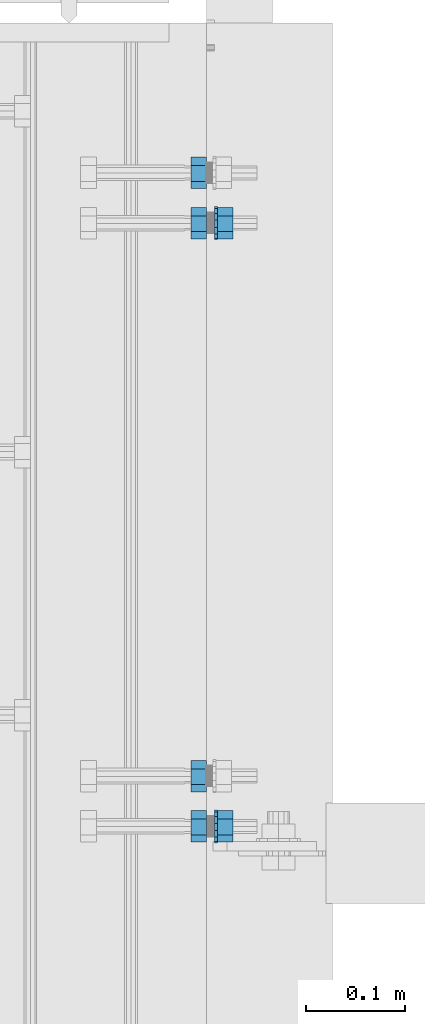
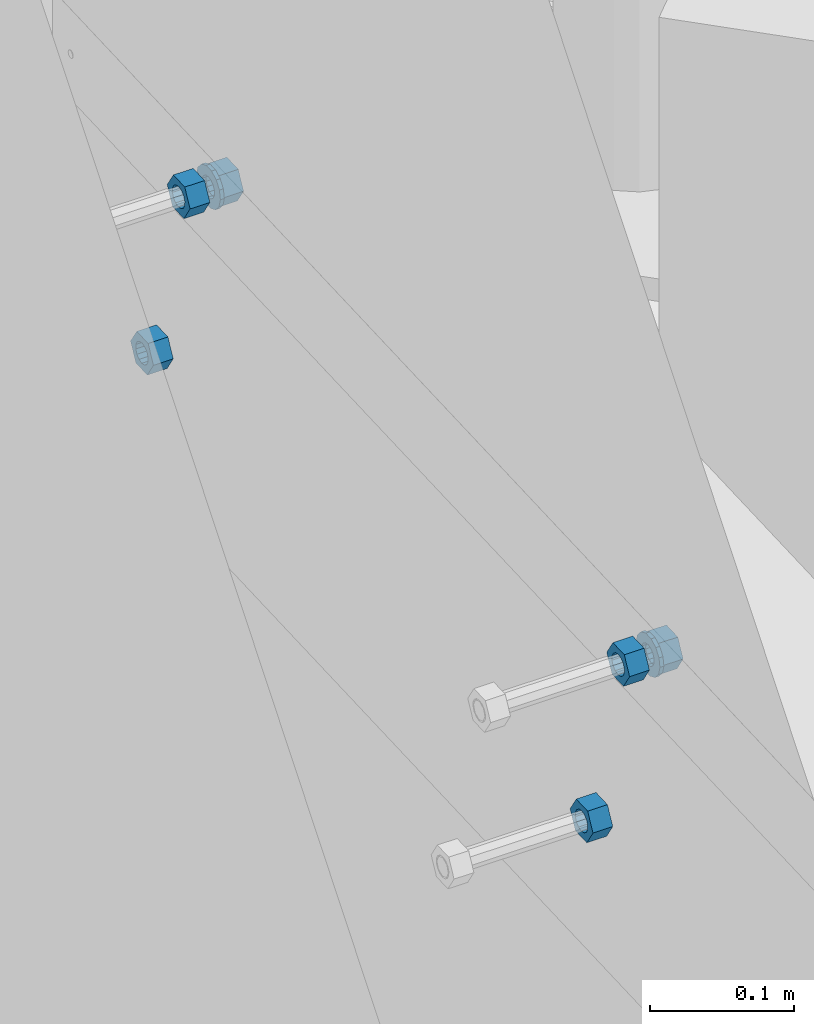
# One storey, part 718 of 975: 8 beams.
"""IFC2X3 building model written with IfcOpenShell, lengths in millimetres."""

from ifc_helpers import new_model, si_unit, frame, origin_with_axes, place, context, subcontext, project, spatial, faceted_brep, material, type_object, element, save


model = new_model("IFC2X3")

# Units and contexts
model_context = context("Model", 3, precision=1e-05, world=origin_with_axes())
body_context = subcontext(model_context, "Body", "Model", "MODEL_VIEW")
ifc_project = project(units=[si_unit("LENGTHUNIT", "METRE", prefix="MILLI"), si_unit("AREAUNIT", "SQUARE_METRE"), si_unit("VOLUMEUNIT", "CUBIC_METRE"), si_unit("MASSUNIT", "GRAM", prefix="KILO"), si_unit("TIMEUNIT", "SECOND"), si_unit("PLANEANGLEUNIT", "RADIAN"), si_unit("SOLIDANGLEUNIT", "STERADIAN"), si_unit("THERMODYNAMICTEMPERATUREUNIT", "DEGREE_CELSIUS"), si_unit("LUMINOUSINTENSITYUNIT", "LUMEN")], contexts=[model_context])

# Site, building, storey
site_placement = place(None, origin_with_axes())
site = spatial("IfcSite", under=ifc_project, at=site_placement, CompositionType="ELEMENT")
building_placement = place(site_placement, origin_with_axes())
building = spatial("IfcBuilding", under=site, at=building_placement, Name="Undefined", CompositionType="ELEMENT")
storey_placement = place(building_placement, origin_with_axes())
storey = spatial("IfcBuildingStorey", under=building, at=storey_placement, Name="Undefined", CompositionType="ELEMENT", Elevation=0.0)

# Beams
ifc_material = material(Name="STEEL/F1554-36")
beam_type_1 = type_object("IfcBeamType", Name="5/8_HEAVY_HEX_NUT", PredefinedType="NOTDEFINED")
beam_1_placement = place(storey_placement, frame((29959.2999142996, 4090.67007810735, 6995.95564941573), z_axis=(3.96407267544419e-09, 0.0430877640020053, -0.999071291046494), x_axis=(-0.999999999999998, 6.90000001668524e-08, 0.0)))
element("IfcBeam", 1, at=beam_1_placement, inside=storey, type_object=beam_type_1, material=ifc_material, Name="HEADED_ANCHOR_BOLT", ObjectType="5/8_HEAVY_HEX_NUT", context=body_context, shape_type="Brep", body=[
    faceted_brep([(-1.09139364212751e-11, -15.8800001144436, -2.72848410531878e-12), (1.45519152283669e-11, -7.94000005722046, -13.7500000000036), (15.8750000000146, -7.94000005722137, -13.7500000000045), (15.8749999999891, -15.8800001144446, -2.72848410531878e-12), (2.91038304567337e-11, 7.94000005722319, -13.7500000000027), (15.8750000000291, 7.94000005722319, -13.7500000000027), (2.18278728425503e-11, 15.8800001144436, 9.09494701772928e-13), (15.8750000000218, 15.8800001144427, 9.09494701772928e-13), (-7.27595761418343e-12, 7.94000005722046, 13.7500000000027), (15.8749999999927, 7.94000005722046, 13.7500000000027), (-2.18278728425503e-11, -7.94000005722228, 13.7500000000009), (15.8749999999782, -7.94000005722319, 13.7500000000009), (-7.27595761418343e-12, 0.0, 8.72999954223724), (0.0, 3.78780484388062, 7.86545780435881), (15.875, 3.78780484387971, 7.86545780435881), (15.8749999999927, -9.09494701772928e-13, 8.72999954223724), (7.27595761418343e-12, 6.82538848405238, 5.44306568481716), (15.8750000000073, 6.82538848405238, 5.44306568481716), (1.09139364212751e-11, 8.51112022706275, 1.94260765157742), (15.8750000000109, 8.51112022706093, 1.94260765157651), (1.45519152283669e-11, 8.51112022706184, -1.94260765157651), (15.8750000000146, 8.51112022706184, -1.94260765157651), (2.18278728425503e-11, 6.8253884840542, -5.44306568481716), (15.8750000000218, 6.82538848405238, -5.44306568481716), (1.81898940354586e-11, 3.78780484388153, -7.86545780435881), (15.8750000000182, 3.78780484388062, -7.86545780435881), (1.81898940354586e-11, 9.09494701772928e-13, -8.72999954223997), (15.8750000000182, 9.09494701772928e-13, -8.72999954223997), (1.09139364212751e-11, -3.78780484387971, -7.86545780436063), (15.8750000000109, -3.78780484388062, -7.86545780436063), (3.63797880709171e-12, -6.82538848405238, -5.44306568481807), (15.8750000000036, -6.82538848405329, -5.44306568481807), (0.0, -8.51112022706184, -1.94260765157833), (15.875, -8.51112022706184, -1.94260765157833), (-7.27595761418343e-12, -8.51112022706184, 1.9426076515756), (15.8749999999927, -8.51112022706275, 1.9426076515756), (-1.09139364212751e-11, -6.82538848405329, 5.44306568481534), (15.8749999999927, -6.8253884840542, 5.44306568481534), (-7.27595761418343e-12, -3.78780484388062, 7.8654578043579), (15.8749999999927, -3.78780484388153, 7.8654578043579)], [[[0, 1, 2, 3]], [[1, 4, 5, 2]], [[4, 6, 7, 5]], [[6, 8, 9, 7]], [[8, 10, 11, 9]], [[10, 0, 3, 11]], [[12, 13, 14, 15]], [[13, 16, 17, 14]], [[16, 18, 19, 17]], [[18, 20, 21, 19]], [[20, 22, 23, 21]], [[22, 24, 25, 23]], [[24, 26, 27, 25]], [[26, 28, 29, 27]], [[28, 30, 31, 29]], [[30, 32, 33, 31]], [[32, 34, 35, 33]], [[34, 36, 37, 35]], [[36, 38, 39, 37]], [[38, 12, 15, 39]], [[5, 7, 9, 11, 3, 2], [17, 19, 21, 23, 25, 27, 29, 31, 33, 35, 37, 39, 15, 14]], [[10, 8, 6, 4, 1, 0], [38, 36, 34, 32, 30, 28, 26, 24, 22, 20, 18, 16, 13, 12]]]),
])
beam_2_placement = place(storey_placement, frame((29959.299898448, 3481.63621908544, 6969.68934848015), z_axis=(3.96407267544419e-09, 0.0430877640020053, -0.999071291046494), x_axis=(-0.999999999999998, 6.90000001668524e-08, 0.0)))
element("IfcBeam", 2, at=beam_2_placement, inside=storey, type_object=beam_type_1, material=ifc_material, Name="HEADED_ANCHOR_BOLT", ObjectType="5/8_HEAVY_HEX_NUT", context=body_context, shape_type="Brep", body=[
    faceted_brep([(-1.09139364212751e-11, -15.8800001144436, -2.72848410531878e-12), (1.45519152283669e-11, -7.94000005722046, -13.7500000000036), (15.8750000000146, -7.94000005722137, -13.7500000000045), (15.8749999999891, -15.8800001144446, -2.72848410531878e-12), (2.91038304567337e-11, 7.94000005722319, -13.7500000000027), (15.8750000000291, 7.94000005722319, -13.7500000000027), (2.18278728425503e-11, 15.8800001144436, 9.09494701772928e-13), (15.8750000000218, 15.8800001144427, 9.09494701772928e-13), (-7.27595761418343e-12, 7.94000005722046, 13.7500000000027), (15.8749999999927, 7.94000005722046, 13.7500000000027), (-2.18278728425503e-11, -7.94000005722228, 13.7500000000009), (15.8749999999782, -7.94000005722319, 13.7500000000009), (-7.27595761418343e-12, 0.0, 8.72999954223724), (0.0, 3.78780484388062, 7.86545780435881), (15.875, 3.78780484387971, 7.86545780435881), (15.8749999999927, -9.09494701772928e-13, 8.72999954223724), (7.27595761418343e-12, 6.82538848405238, 5.44306568481716), (15.8750000000073, 6.82538848405238, 5.44306568481716), (1.09139364212751e-11, 8.51112022706275, 1.94260765157742), (15.8750000000109, 8.51112022706093, 1.94260765157651), (1.45519152283669e-11, 8.51112022706184, -1.94260765157651), (15.8750000000146, 8.51112022706184, -1.94260765157651), (2.18278728425503e-11, 6.8253884840542, -5.44306568481716), (15.8750000000218, 6.82538848405238, -5.44306568481716), (1.81898940354586e-11, 3.78780484388153, -7.86545780435881), (15.8750000000182, 3.78780484388062, -7.86545780435881), (1.81898940354586e-11, 9.09494701772928e-13, -8.72999954223997), (15.8750000000182, 9.09494701772928e-13, -8.72999954223997), (1.09139364212751e-11, -3.78780484387971, -7.86545780436063), (15.8750000000109, -3.78780484388062, -7.86545780436063), (3.63797880709171e-12, -6.82538848405238, -5.44306568481807), (15.8750000000036, -6.82538848405329, -5.44306568481807), (0.0, -8.51112022706184, -1.94260765157833), (15.875, -8.51112022706184, -1.94260765157833), (-7.27595761418343e-12, -8.51112022706184, 1.9426076515756), (15.8749999999927, -8.51112022706275, 1.9426076515756), (-1.09139364212751e-11, -6.82538848405329, 5.44306568481534), (15.8749999999927, -6.8253884840542, 5.44306568481534), (-7.27595761418343e-12, -3.78780484388062, 7.8654578043579), (15.8749999999927, -3.78780484388153, 7.8654578043579)], [[[0, 1, 2, 3]], [[1, 4, 5, 2]], [[4, 6, 7, 5]], [[6, 8, 9, 7]], [[8, 10, 11, 9]], [[10, 0, 3, 11]], [[12, 13, 14, 15]], [[13, 16, 17, 14]], [[16, 18, 19, 17]], [[18, 20, 21, 19]], [[20, 22, 23, 21]], [[22, 24, 25, 23]], [[24, 26, 27, 25]], [[26, 28, 29, 27]], [[28, 30, 31, 29]], [[30, 32, 33, 31]], [[32, 34, 35, 33]], [[34, 36, 37, 35]], [[36, 38, 39, 37]], [[38, 12, 15, 39]], [[5, 7, 9, 11, 3, 2], [17, 19, 21, 23, 25, 27, 29, 31, 33, 35, 37, 39, 15, 14]], [[10, 8, 6, 4, 1, 0], [38, 36, 34, 32, 30, 28, 26, 24, 22, 20, 18, 16, 13, 12]]]),
])
beam_3_placement = place(storey_placement, frame((29959.2996283393, 4039.92666630224, 7159.02066960924), z_axis=(-7.0905516622588e-09, -0.0430877640020049, 0.999071291046494), x_axis=(-0.999999999999998, 6.90000001668524e-08, 0.0)))
element("IfcBeam", 3, at=beam_3_placement, inside=storey, type_object=beam_type_1, material=ifc_material, Name="HEADED_ANCHOR_BOLT", ObjectType="5/8_HEAVY_HEX_NUT", context=body_context, shape_type="Brep", body=[
    faceted_brep([(-1.09139364212751e-11, -15.8800001144436, -2.72848410531878e-12), (1.45519152283669e-11, -7.94000005722046, -13.7500000000036), (15.8750000000146, -7.94000005722137, -13.7500000000045), (15.8749999999891, -15.8800001144446, -2.72848410531878e-12), (2.91038304567337e-11, 7.94000005722319, -13.7500000000027), (15.8750000000291, 7.94000005722319, -13.7500000000027), (2.18278728425503e-11, 15.8800001144436, 9.09494701772928e-13), (15.8750000000218, 15.8800001144427, 9.09494701772928e-13), (-7.27595761418343e-12, 7.94000005722046, 13.7500000000027), (15.8749999999927, 7.94000005722046, 13.7500000000027), (-2.18278728425503e-11, -7.94000005722228, 13.7500000000009), (15.8749999999782, -7.94000005722319, 13.7500000000009), (-7.27595761418343e-12, 0.0, 8.72999954223724), (0.0, 3.78780484388062, 7.86545780435881), (15.875, 3.78780484387971, 7.86545780435881), (15.8749999999927, -9.09494701772928e-13, 8.72999954223724), (7.27595761418343e-12, 6.82538848405238, 5.44306568481716), (15.8750000000073, 6.82538848405238, 5.44306568481716), (1.09139364212751e-11, 8.51112022706275, 1.94260765157742), (15.8750000000109, 8.51112022706093, 1.94260765157651), (1.45519152283669e-11, 8.51112022706184, -1.94260765157651), (15.8750000000146, 8.51112022706184, -1.94260765157651), (2.18278728425503e-11, 6.8253884840542, -5.44306568481716), (15.8750000000218, 6.82538848405238, -5.44306568481716), (1.81898940354586e-11, 3.78780484388153, -7.86545780435881), (15.8750000000182, 3.78780484388062, -7.86545780435881), (1.81898940354586e-11, 9.09494701772928e-13, -8.72999954223997), (15.8750000000182, 9.09494701772928e-13, -8.72999954223997), (1.09139364212751e-11, -3.78780484387971, -7.86545780436063), (15.8750000000109, -3.78780484388062, -7.86545780436063), (3.63797880709171e-12, -6.82538848405238, -5.44306568481807), (15.8750000000036, -6.82538848405329, -5.44306568481807), (0.0, -8.51112022706184, -1.94260765157833), (15.875, -8.51112022706184, -1.94260765157833), (-7.27595761418343e-12, -8.51112022706184, 1.9426076515756), (15.8749999999927, -8.51112022706275, 1.9426076515756), (-1.09139364212751e-11, -6.82538848405329, 5.44306568481534), (15.8749999999927, -6.8253884840542, 5.44306568481534), (-7.27595761418343e-12, -3.78780484388062, 7.8654578043579), (15.8749999999927, -3.78780484388153, 7.8654578043579)], [[[0, 1, 2, 3]], [[1, 4, 5, 2]], [[4, 6, 7, 5]], [[6, 8, 9, 7]], [[8, 10, 11, 9]], [[10, 0, 3, 11]], [[12, 13, 14, 15]], [[13, 16, 17, 14]], [[16, 18, 19, 17]], [[18, 20, 21, 19]], [[20, 22, 23, 21]], [[22, 24, 25, 23]], [[24, 26, 27, 25]], [[26, 28, 29, 27]], [[28, 30, 31, 29]], [[30, 32, 33, 31]], [[32, 34, 35, 33]], [[34, 36, 37, 35]], [[36, 38, 39, 37]], [[38, 12, 15, 39]], [[5, 7, 9, 11, 3, 2], [17, 19, 21, 23, 25, 27, 29, 31, 33, 35, 37, 39, 15, 14]], [[10, 8, 6, 4, 1, 0], [38, 36, 34, 32, 30, 28, 26, 24, 22, 20, 18, 16, 13, 12]]]),
])
beam_4_placement = place(storey_placement, frame((29986.2871283396, 4039.92667104132, 7159.02066965644), z_axis=(-7.0905516622588e-09, -0.0430877640020049, 0.999071291046494), x_axis=(-0.999999999999998, 6.90000001668524e-08, 0.0)))
element("IfcBeam", 4, at=beam_4_placement, inside=storey, type_object=beam_type_1, material=ifc_material, Name="HEADED_ANCHOR_BOLT", ObjectType="5/8_HEAVY_HEX_NUT", context=body_context, shape_type="Brep", body=[
    faceted_brep([(-1.09139364212751e-11, -15.8800001144436, -2.72848410531878e-12), (1.45519152283669e-11, -7.94000005722046, -13.7500000000036), (15.8750000000146, -7.94000005722137, -13.7500000000045), (15.8749999999891, -15.8800001144446, -2.72848410531878e-12), (2.91038304567337e-11, 7.94000005722319, -13.7500000000027), (15.8750000000291, 7.94000005722319, -13.7500000000027), (2.18278728425503e-11, 15.8800001144436, 9.09494701772928e-13), (15.8750000000218, 15.8800001144427, 9.09494701772928e-13), (-7.27595761418343e-12, 7.94000005722046, 13.7500000000027), (15.8749999999927, 7.94000005722046, 13.7500000000027), (-2.18278728425503e-11, -7.94000005722228, 13.7500000000009), (15.8749999999782, -7.94000005722319, 13.7500000000009), (-7.27595761418343e-12, 0.0, 8.72999954223724), (0.0, 3.78780484388062, 7.86545780435881), (15.875, 3.78780484387971, 7.86545780435881), (15.8749999999927, -9.09494701772928e-13, 8.72999954223724), (7.27595761418343e-12, 6.82538848405238, 5.44306568481716), (15.8750000000073, 6.82538848405238, 5.44306568481716), (1.09139364212751e-11, 8.51112022706275, 1.94260765157742), (15.8750000000109, 8.51112022706093, 1.94260765157651), (1.45519152283669e-11, 8.51112022706184, -1.94260765157651), (15.8750000000146, 8.51112022706184, -1.94260765157651), (2.18278728425503e-11, 6.8253884840542, -5.44306568481716), (15.8750000000218, 6.82538848405238, -5.44306568481716), (1.81898940354586e-11, 3.78780484388153, -7.86545780435881), (15.8750000000182, 3.78780484388062, -7.86545780435881), (1.81898940354586e-11, 9.09494701772928e-13, -8.72999954223997), (15.8750000000182, 9.09494701772928e-13, -8.72999954223997), (1.09139364212751e-11, -3.78780484387971, -7.86545780436063), (15.8750000000109, -3.78780484388062, -7.86545780436063), (3.63797880709171e-12, -6.82538848405238, -5.44306568481807), (15.8750000000036, -6.82538848405329, -5.44306568481807), (0.0, -8.51112022706184, -1.94260765157833), (15.875, -8.51112022706184, -1.94260765157833), (-7.27595761418343e-12, -8.51112022706184, 1.9426076515756), (15.8749999999927, -8.51112022706275, 1.9426076515756), (-1.09139364212751e-11, -6.82538848405329, 5.44306568481534), (15.8749999999927, -6.8253884840542, 5.44306568481534), (-7.27595761418343e-12, -3.78780484388062, 7.8654578043579), (15.8749999999927, -3.78780484388153, 7.8654578043579)], [[[0, 1, 2, 3]], [[1, 4, 5, 2]], [[4, 6, 7, 5]], [[6, 8, 9, 7]], [[8, 10, 11, 9]], [[10, 0, 3, 11]], [[12, 13, 14, 15]], [[13, 16, 17, 14]], [[16, 18, 19, 17]], [[18, 20, 21, 19]], [[20, 22, 23, 21]], [[22, 24, 25, 23]], [[24, 26, 27, 25]], [[26, 28, 29, 27]], [[28, 30, 31, 29]], [[30, 32, 33, 31]], [[32, 34, 35, 33]], [[34, 36, 37, 35]], [[36, 38, 39, 37]], [[38, 12, 15, 39]], [[5, 7, 9, 11, 3, 2], [17, 19, 21, 23, 25, 27, 29, 31, 33, 35, 37, 39, 15, 14]], [[10, 8, 6, 4, 1, 0], [38, 36, 34, 32, 30, 28, 26, 24, 22, 20, 18, 16, 13, 12]]]),
])
beam_5_placement = place(storey_placement, frame((29959.2996801553, 3430.89283167165, 7132.75436972556), z_axis=(-7.0905516622588e-09, -0.0430877640020049, 0.999071291046494), x_axis=(-0.999999999999998, 6.90000001668524e-08, 0.0)))
element("IfcBeam", 5, at=beam_5_placement, inside=storey, type_object=beam_type_1, material=ifc_material, Name="HEADED_ANCHOR_BOLT", ObjectType="5/8_HEAVY_HEX_NUT", context=body_context, shape_type="Brep", body=[
    faceted_brep([(-1.09139364212751e-11, -15.8800001144436, -2.72848410531878e-12), (1.45519152283669e-11, -7.94000005722046, -13.7500000000036), (15.8750000000146, -7.94000005722137, -13.7500000000045), (15.8749999999891, -15.8800001144446, -2.72848410531878e-12), (2.91038304567337e-11, 7.94000005722319, -13.7500000000027), (15.8750000000291, 7.94000005722319, -13.7500000000027), (2.18278728425503e-11, 15.8800001144436, 9.09494701772928e-13), (15.8750000000218, 15.8800001144427, 9.09494701772928e-13), (-7.27595761418343e-12, 7.94000005722046, 13.7500000000027), (15.8749999999927, 7.94000005722046, 13.7500000000027), (-2.18278728425503e-11, -7.94000005722228, 13.7500000000009), (15.8749999999782, -7.94000005722319, 13.7500000000009), (-7.27595761418343e-12, 0.0, 8.72999954223724), (0.0, 3.78780484388062, 7.86545780435881), (15.875, 3.78780484387971, 7.86545780435881), (15.8749999999927, -9.09494701772928e-13, 8.72999954223724), (7.27595761418343e-12, 6.82538848405238, 5.44306568481716), (15.8750000000073, 6.82538848405238, 5.44306568481716), (1.09139364212751e-11, 8.51112022706275, 1.94260765157742), (15.8750000000109, 8.51112022706093, 1.94260765157651), (1.45519152283669e-11, 8.51112022706184, -1.94260765157651), (15.8750000000146, 8.51112022706184, -1.94260765157651), (2.18278728425503e-11, 6.8253884840542, -5.44306568481716), (15.8750000000218, 6.82538848405238, -5.44306568481716), (1.81898940354586e-11, 3.78780484388153, -7.86545780435881), (15.8750000000182, 3.78780484388062, -7.86545780435881), (1.81898940354586e-11, 9.09494701772928e-13, -8.72999954223997), (15.8750000000182, 9.09494701772928e-13, -8.72999954223997), (1.09139364212751e-11, -3.78780484387971, -7.86545780436063), (15.8750000000109, -3.78780484388062, -7.86545780436063), (3.63797880709171e-12, -6.82538848405238, -5.44306568481807), (15.8750000000036, -6.82538848405329, -5.44306568481807), (0.0, -8.51112022706184, -1.94260765157833), (15.875, -8.51112022706184, -1.94260765157833), (-7.27595761418343e-12, -8.51112022706184, 1.9426076515756), (15.8749999999927, -8.51112022706275, 1.9426076515756), (-1.09139364212751e-11, -6.82538848405329, 5.44306568481534), (15.8749999999927, -6.8253884840542, 5.44306568481534), (-7.27595761418343e-12, -3.78780484388062, 7.8654578043579), (15.8749999999927, -3.78780484388153, 7.8654578043579)], [[[0, 1, 2, 3]], [[1, 4, 5, 2]], [[4, 6, 7, 5]], [[6, 8, 9, 7]], [[8, 10, 11, 9]], [[10, 0, 3, 11]], [[12, 13, 14, 15]], [[13, 16, 17, 14]], [[16, 18, 19, 17]], [[18, 20, 21, 19]], [[20, 22, 23, 21]], [[22, 24, 25, 23]], [[24, 26, 27, 25]], [[26, 28, 29, 27]], [[28, 30, 31, 29]], [[30, 32, 33, 31]], [[32, 34, 35, 33]], [[34, 36, 37, 35]], [[36, 38, 39, 37]], [[38, 12, 15, 39]], [[5, 7, 9, 11, 3, 2], [17, 19, 21, 23, 25, 27, 29, 31, 33, 35, 37, 39, 15, 14]], [[10, 8, 6, 4, 1, 0], [38, 36, 34, 32, 30, 28, 26, 24, 22, 20, 18, 16, 13, 12]]]),
])
beam_6_placement = place(storey_placement, frame((29986.2871801556, 3430.89283641073, 7132.75436977276), z_axis=(-7.0905516622588e-09, -0.0430877640020049, 0.999071291046494), x_axis=(-0.999999999999998, 6.90000001668524e-08, 0.0)))
element("IfcBeam", 6, at=beam_6_placement, inside=storey, type_object=beam_type_1, material=ifc_material, Name="HEADED_ANCHOR_BOLT", ObjectType="5/8_HEAVY_HEX_NUT", context=body_context, shape_type="Brep", body=[
    faceted_brep([(-1.09139364212751e-11, -15.8800001144436, -2.72848410531878e-12), (1.45519152283669e-11, -7.94000005722046, -13.7500000000036), (15.8750000000146, -7.94000005722137, -13.7500000000045), (15.8749999999891, -15.8800001144446, -2.72848410531878e-12), (2.91038304567337e-11, 7.94000005722319, -13.7500000000027), (15.8750000000291, 7.94000005722319, -13.7500000000027), (2.18278728425503e-11, 15.8800001144436, 9.09494701772928e-13), (15.8750000000218, 15.8800001144427, 9.09494701772928e-13), (-7.27595761418343e-12, 7.94000005722046, 13.7500000000027), (15.8749999999927, 7.94000005722046, 13.7500000000027), (-2.18278728425503e-11, -7.94000005722228, 13.7500000000009), (15.8749999999782, -7.94000005722319, 13.7500000000009), (-7.27595761418343e-12, 0.0, 8.72999954223724), (0.0, 3.78780484388062, 7.86545780435881), (15.875, 3.78780484387971, 7.86545780435881), (15.8749999999927, -9.09494701772928e-13, 8.72999954223724), (7.27595761418343e-12, 6.82538848405238, 5.44306568481716), (15.8750000000073, 6.82538848405238, 5.44306568481716), (1.09139364212751e-11, 8.51112022706275, 1.94260765157742), (15.8750000000109, 8.51112022706093, 1.94260765157651), (1.45519152283669e-11, 8.51112022706184, -1.94260765157651), (15.8750000000146, 8.51112022706184, -1.94260765157651), (2.18278728425503e-11, 6.8253884840542, -5.44306568481716), (15.8750000000218, 6.82538848405238, -5.44306568481716), (1.81898940354586e-11, 3.78780484388153, -7.86545780435881), (15.8750000000182, 3.78780484388062, -7.86545780435881), (1.81898940354586e-11, 9.09494701772928e-13, -8.72999954223997), (15.8750000000182, 9.09494701772928e-13, -8.72999954223997), (1.09139364212751e-11, -3.78780484387971, -7.86545780436063), (15.8750000000109, -3.78780484388062, -7.86545780436063), (3.63797880709171e-12, -6.82538848405238, -5.44306568481807), (15.8750000000036, -6.82538848405329, -5.44306568481807), (0.0, -8.51112022706184, -1.94260765157833), (15.875, -8.51112022706184, -1.94260765157833), (-7.27595761418343e-12, -8.51112022706184, 1.9426076515756), (15.8749999999927, -8.51112022706275, 1.9426076515756), (-1.09139364212751e-11, -6.82538848405329, 5.44306568481534), (15.8749999999927, -6.8253884840542, 5.44306568481534), (-7.27595761418343e-12, -3.78780484388062, 7.8654578043579), (15.8749999999927, -3.78780484388153, 7.8654578043579)], [[[0, 1, 2, 3]], [[1, 4, 5, 2]], [[4, 6, 7, 5]], [[6, 8, 9, 7]], [[8, 10, 11, 9]], [[10, 0, 3, 11]], [[12, 13, 14, 15]], [[13, 16, 17, 14]], [[16, 18, 19, 17]], [[18, 20, 21, 19]], [[20, 22, 23, 21]], [[22, 24, 25, 23]], [[24, 26, 27, 25]], [[26, 28, 29, 27]], [[28, 30, 31, 29]], [[30, 32, 33, 31]], [[32, 34, 35, 33]], [[34, 36, 37, 35]], [[36, 38, 39, 37]], [[38, 12, 15, 39]], [[5, 7, 9, 11, 3, 2], [17, 19, 21, 23, 25, 27, 29, 31, 33, 35, 37, 39, 15, 14]], [[10, 8, 6, 4, 1, 0], [38, 36, 34, 32, 30, 28, 26, 24, 22, 20, 18, 16, 13, 12]]]),
])
beam_type_2 = type_object("IfcBeamType", Name="5/8_WASHER", PredefinedType="NOTDEFINED")
beam_7_placement = place(storey_placement, frame((29970.4121283397, 4039.92666819858, 7159.02066967837), z_axis=(-7.0905516622588e-09, -0.0430877640020049, 0.999071291046494), x_axis=(-0.999999999999998, 6.90000001668524e-08, 0.0)))
element("IfcBeam", 7, at=beam_7_placement, inside=storey, type_object=beam_type_2, material=ifc_material, Name="HEADED_ANCHOR_BOLT", ObjectType="5/8_WASHER", context=body_context, shape_type="Brep", body=[
    faceted_brep([(1.09139364212751e-11, -16.670000076293, -2.72848410531878e-12), (2.18278728425503e-11, -15.0191510966704, -7.23284196419536), (3.1750000000211, -15.0191510966711, -7.23284196419627), (3.17500000001019, -16.6700000762937, -1.81898940354586e-12), (2.91038304567337e-11, -10.3935750445523, -13.0331308723944), (3.17500000002838, -10.3935750445526, -13.0331308723953), (2.91038304567337e-11, -3.70942398602756, -16.2520483704566), (3.17500000002838, -3.70942398602779, -16.2520483704566), (2.5465851649642e-11, 3.70942398602961, -16.2520483704557), (3.17500000002474, 3.70942398602961, -16.2520483704566), (1.45519152283669e-11, 10.3935750445542, -13.0331308723935), (3.17500000001382, 10.3935750445537, -13.0331308723944), (0.0, 15.0191510966717, -7.23284196419354), (3.17499999999927, 15.0191510966713, -7.23284196419354), (-7.27595761418343e-12, 16.6700000762933, 0.0), (3.174999999992, 16.6700000762928, -9.09494701772928e-13), (-1.81898940354586e-11, 15.0191510966706, 7.23284196419354), (3.17499999998108, 15.0191510966704, 7.23284196419354), (-2.5465851649642e-11, 10.3935750445519, 13.0331308723926), (3.17499999997381, 10.3935750445517, 13.0331308723926), (-2.5465851649642e-11, 3.70942398602733, 16.2520483704538), (3.17499999997381, 3.7094239860271, 16.2520483704529), (-2.18278728425503e-11, -3.70942398602983, 16.2520483704529), (3.17499999997744, -3.70942398603006, 16.2520483704538), (-1.09139364212751e-11, -10.3935750445542, 13.0331308723908), (3.17499999998836, -10.3935750445544, 13.0331308723908), (0.0, -15.0191510966717, 7.23284196419172), (3.17499999999927, -15.019151096672, 7.23284196419081), (-7.27595761418343e-12, 0.0, 8.72999954223724), (0.0, 3.78780484388062, 7.86545780435881), (3.17499999998472, 3.78780484387903, 7.86545780435699), (3.17499999998836, -9.09494701772928e-13, 8.72999954223542), (7.27595761418343e-12, 6.82538848405238, 5.44306568481716), (3.17499999998836, 6.82538848405102, 5.44306568481534), (1.09139364212751e-11, 8.51112022706275, 1.94260765157742), (3.174999999992, 8.51112022705979, 1.94260765157651), (1.45519152283669e-11, 8.51112022706184, -1.94260765157651), (3.17499999999563, 8.51112022706025, -1.94260765157742), (2.18278728425503e-11, 6.8253884840542, -5.44306568481716), (3.17500000000655, 6.8253884840517, -5.44306568481807), (1.81898940354586e-11, 3.78780484388153, -7.86545780435881), (3.17500000001019, 3.78780484388017, -7.86545780435972), (1.81898940354586e-11, 9.09494701772928e-13, -8.72999954223997), (3.17500000001382, 6.82121026329696e-13, -8.72999954223997), (1.09139364212751e-11, -3.78780484387971, -7.86545780436063), (3.17500000001382, -3.78780484387994, -7.86545780436063), (3.63797880709171e-12, -6.82538848405238, -5.44306568481807), (3.17500000001019, -6.82538848405147, -5.44306568481898), (0.0, -8.51112022706184, -1.94260765157833), (3.17500000001019, -8.5111202270607, -1.94260765157924), (-7.27595761418343e-12, -8.51112022706184, 1.9426076515756), (3.17500000000291, -8.51112022706093, 1.94260765157469), (-1.09139364212751e-11, -6.82538848405329, 5.44306568481534), (3.17499999999563, -6.82538848405238, 5.44306568481534), (-7.27595761418343e-12, -3.78780484388062, 7.8654578043579), (3.174999999992, -3.78780484388085, 7.86545780435699)], [[[0, 1, 2, 3]], [[1, 4, 5, 2]], [[4, 6, 7, 5]], [[6, 8, 9, 7]], [[8, 10, 11, 9]], [[10, 12, 13, 11]], [[12, 14, 15, 13]], [[14, 16, 17, 15]], [[16, 18, 19, 17]], [[18, 20, 21, 19]], [[20, 22, 23, 21]], [[22, 24, 25, 23]], [[24, 26, 27, 25]], [[26, 0, 3, 27]], [[28, 29, 30, 31]], [[29, 32, 33, 30]], [[32, 34, 35, 33]], [[34, 36, 37, 35]], [[36, 38, 39, 37]], [[38, 40, 41, 39]], [[40, 42, 43, 41]], [[42, 44, 45, 43]], [[44, 46, 47, 45]], [[46, 48, 49, 47]], [[48, 50, 51, 49]], [[50, 52, 53, 51]], [[52, 54, 55, 53]], [[54, 28, 31, 55]], [[5, 7, 9, 11, 13, 15, 17, 19, 21, 23, 25, 27, 3, 2], [33, 35, 37, 39, 41, 43, 45, 47, 49, 51, 53, 55, 31, 30]], [[26, 24, 22, 20, 18, 16, 14, 12, 10, 8, 6, 4, 1, 0], [54, 52, 50, 48, 46, 44, 42, 40, 38, 36, 34, 32, 29, 28]]]),
])
beam_8_placement = place(storey_placement, frame((29970.4121801557, 3430.89283356799, 7132.75436979469), z_axis=(-7.0905516622588e-09, -0.0430877640020049, 0.999071291046494), x_axis=(-0.999999999999998, 6.90000001668524e-08, 0.0)))
element("IfcBeam", 8, at=beam_8_placement, inside=storey, type_object=beam_type_2, material=ifc_material, Name="HEADED_ANCHOR_BOLT", ObjectType="5/8_WASHER", context=body_context, shape_type="Brep", body=[
    faceted_brep([(1.09139364212751e-11, -16.670000076293, -2.72848410531878e-12), (2.18278728425503e-11, -15.0191510966704, -7.23284196419536), (3.1750000000211, -15.0191510966711, -7.23284196419627), (3.17500000001019, -16.6700000762937, -1.81898940354586e-12), (2.91038304567337e-11, -10.3935750445523, -13.0331308723944), (3.17500000002838, -10.3935750445526, -13.0331308723953), (2.91038304567337e-11, -3.70942398602756, -16.2520483704566), (3.17500000002838, -3.70942398602779, -16.2520483704566), (2.5465851649642e-11, 3.70942398602961, -16.2520483704557), (3.17500000002474, 3.70942398602961, -16.2520483704566), (1.45519152283669e-11, 10.3935750445542, -13.0331308723935), (3.17500000001382, 10.3935750445537, -13.0331308723944), (0.0, 15.0191510966717, -7.23284196419354), (3.17499999999927, 15.0191510966713, -7.23284196419354), (-7.27595761418343e-12, 16.6700000762933, 0.0), (3.174999999992, 16.6700000762928, -9.09494701772928e-13), (-1.81898940354586e-11, 15.0191510966706, 7.23284196419354), (3.17499999998108, 15.0191510966704, 7.23284196419354), (-2.5465851649642e-11, 10.3935750445519, 13.0331308723926), (3.17499999997381, 10.3935750445517, 13.0331308723926), (-2.5465851649642e-11, 3.70942398602733, 16.2520483704538), (3.17499999997381, 3.7094239860271, 16.2520483704529), (-2.18278728425503e-11, -3.70942398602983, 16.2520483704529), (3.17499999997744, -3.70942398603006, 16.2520483704538), (-1.09139364212751e-11, -10.3935750445542, 13.0331308723908), (3.17499999998836, -10.3935750445544, 13.0331308723908), (0.0, -15.0191510966717, 7.23284196419172), (3.17499999999927, -15.019151096672, 7.23284196419081), (-7.27595761418343e-12, 0.0, 8.72999954223724), (0.0, 3.78780484388062, 7.86545780435881), (3.17499999998472, 3.78780484387903, 7.86545780435699), (3.17499999998836, -9.09494701772928e-13, 8.72999954223542), (7.27595761418343e-12, 6.82538848405238, 5.44306568481716), (3.17499999998836, 6.82538848405102, 5.44306568481534), (1.09139364212751e-11, 8.51112022706275, 1.94260765157742), (3.174999999992, 8.51112022705979, 1.94260765157651), (1.45519152283669e-11, 8.51112022706184, -1.94260765157651), (3.17499999999563, 8.51112022706025, -1.94260765157742), (2.18278728425503e-11, 6.8253884840542, -5.44306568481716), (3.17500000000655, 6.8253884840517, -5.44306568481807), (1.81898940354586e-11, 3.78780484388153, -7.86545780435881), (3.17500000001019, 3.78780484388017, -7.86545780435972), (1.81898940354586e-11, 9.09494701772928e-13, -8.72999954223997), (3.17500000001382, 6.82121026329696e-13, -8.72999954223997), (1.09139364212751e-11, -3.78780484387971, -7.86545780436063), (3.17500000001382, -3.78780484387994, -7.86545780436063), (3.63797880709171e-12, -6.82538848405238, -5.44306568481807), (3.17500000001019, -6.82538848405147, -5.44306568481898), (0.0, -8.51112022706184, -1.94260765157833), (3.17500000001019, -8.5111202270607, -1.94260765157924), (-7.27595761418343e-12, -8.51112022706184, 1.9426076515756), (3.17500000000291, -8.51112022706093, 1.94260765157469), (-1.09139364212751e-11, -6.82538848405329, 5.44306568481534), (3.17499999999563, -6.82538848405238, 5.44306568481534), (-7.27595761418343e-12, -3.78780484388062, 7.8654578043579), (3.174999999992, -3.78780484388085, 7.86545780435699)], [[[0, 1, 2, 3]], [[1, 4, 5, 2]], [[4, 6, 7, 5]], [[6, 8, 9, 7]], [[8, 10, 11, 9]], [[10, 12, 13, 11]], [[12, 14, 15, 13]], [[14, 16, 17, 15]], [[16, 18, 19, 17]], [[18, 20, 21, 19]], [[20, 22, 23, 21]], [[22, 24, 25, 23]], [[24, 26, 27, 25]], [[26, 0, 3, 27]], [[28, 29, 30, 31]], [[29, 32, 33, 30]], [[32, 34, 35, 33]], [[34, 36, 37, 35]], [[36, 38, 39, 37]], [[38, 40, 41, 39]], [[40, 42, 43, 41]], [[42, 44, 45, 43]], [[44, 46, 47, 45]], [[46, 48, 49, 47]], [[48, 50, 51, 49]], [[50, 52, 53, 51]], [[52, 54, 55, 53]], [[54, 28, 31, 55]], [[5, 7, 9, 11, 13, 15, 17, 19, 21, 23, 25, 27, 3, 2], [33, 35, 37, 39, 41, 43, 45, 47, 49, 51, 53, 55, 31, 30]], [[26, 24, 22, 20, 18, 16, 14, 12, 10, 8, 6, 4, 1, 0], [54, 52, 50, 48, 46, 44, 42, 40, 38, 36, 34, 32, 29, 28]]]),
])

save(model, "model.ifc")
